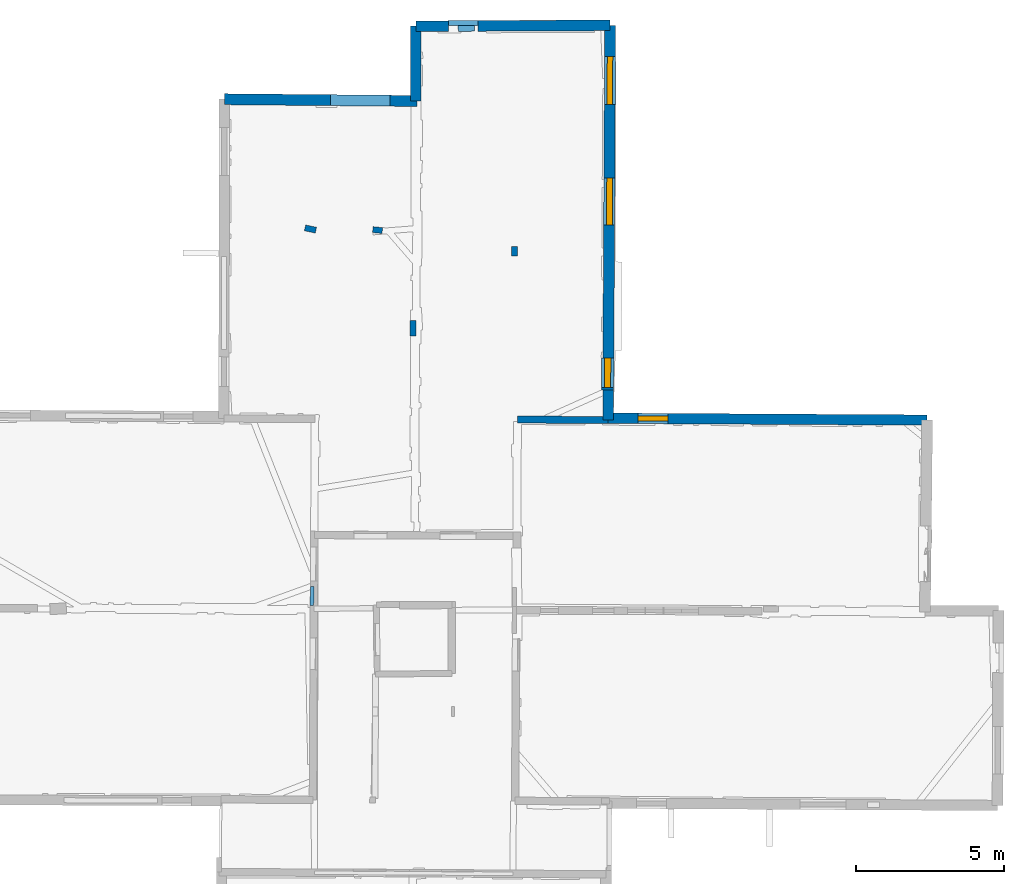
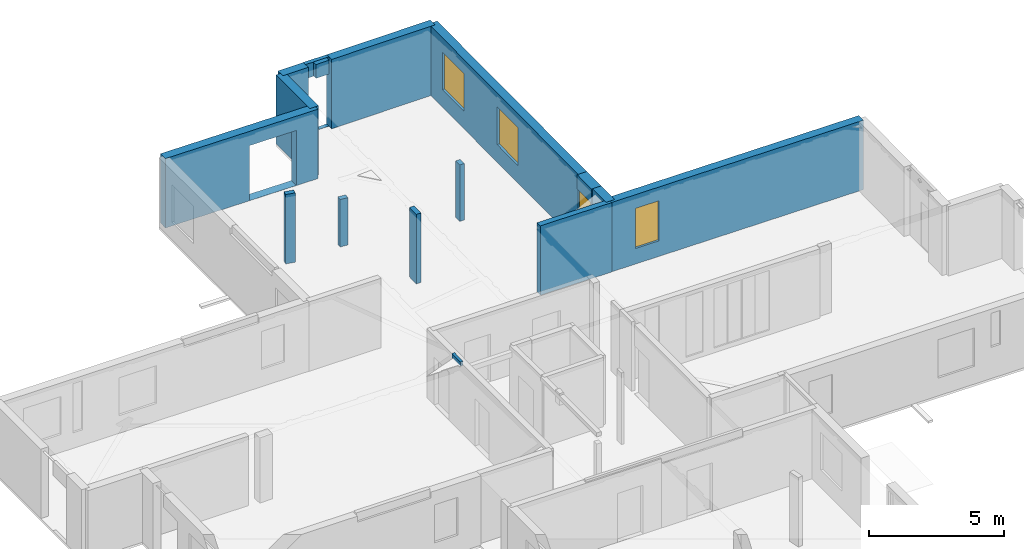
# One storey, part 9 of 14: 16 walls, 4 windows, 6 openings.
"""IFC2X3 building model written with IfcOpenShell, lengths in metres."""

import ifcopenshell
import ifcopenshell.guid

model = None  # the IFC model being written
_history = None  # IfcOwnerHistory: only IFC2X3 demands one
_inside = {}  # id of a spatial element -> (the spatial element, [elements in it])
_under = {}  # id of a project, library or spatial element -> (it, [spatial elements below it])
_declared = {}  # id of a project -> (the project, [libraries it declares])
_typed = {}  # id of a type object -> (the type object, [elements of that type])
_made_of = {}  # id of a material, layer set ... -> (it, [elements and type objects made of it])


def new_model(schema):
    """Start an empty IFC model of exactly this schema.

    Asked for "IFC4X3", IfcOpenShell would pick the latest addendum, in which some entities
    have other attributes; the version numbers below select the first issue.
    IFC2X3 requires an IfcOwnerHistory on every rooted entity: one is made here for all.
    """
    global model, _history
    if schema == "IFC4X3":
        model = ifcopenshell.file(schema_version=(4, 3, 0, 0))
    else:
        model = ifcopenshell.file(schema=schema)
    _inside.clear()
    _under.clear()
    _declared.clear()
    _typed.clear()
    _made_of.clear()
    _history = None
    if model.schema == "IFC2X3":
        org = make("IfcOrganization", Name="unknown")
        user = make(
            "IfcPersonAndOrganization",
            ThePerson=make("IfcPerson", FamilyName="unknown"),
            TheOrganization=org,
        )
        app = make(
            "IfcApplication",
            ApplicationDeveloper=org,
            Version="unknown",
            ApplicationFullName="unknown",
            ApplicationIdentifier="unknown",
        )
        _history = make(
            "IfcOwnerHistory",
            OwningUser=user,
            OwningApplication=app,
            ChangeAction="ADDED",
            CreationDate=0,
        )
    return model


def make(cls, **values):
    """One entity of the class cls with the attributes given. An attribute that is None is left unset."""
    return model.create_entity(
        cls, **{name: value for name, value in values.items() if value is not None}
    )


def entity(cls, *values):
    """Any entity or typed value of the class cls, its attributes in the order of the schema. None: left unset."""
    e = model.create_entity(cls)
    for i, value in enumerate(values):
        if value is not None:
            e[i] = value
    return e


def rooted(cls, **values):
    """An entity with a GlobalId (a new one), such as an element, a storey or a relation."""
    return make(cls, GlobalId=ifcopenshell.guid.new(), OwnerHistory=_history, **values)


def si_unit(unit_type, name, prefix=None):
    """IfcSIUnit, for example si_unit("LENGTHUNIT", "METRE", prefix="MILLI")."""
    return make("IfcSIUnit", UnitType=unit_type, Prefix=prefix, Name=name)


def converted_unit(unit_type, name, factor, base, dimensions=None, offset=None):
    """IfcConversionBasedUnit, such as the inch: factor (a typed value) times the base unit."""
    return make(
        "IfcConversionBasedUnit"
        if offset is None
        else "IfcConversionBasedUnitWithOffset",
        ConversionOffset=offset,
        Dimensions=None
        if dimensions is None
        else entity("IfcDimensionalExponents", *dimensions),
        UnitType=unit_type,
        Name=name,
        ConversionFactor=make(
            "IfcMeasureWithUnit", ValueComponent=factor, UnitComponent=base
        ),
    )


def derived_unit(unit_type, elements):
    """IfcDerivedUnit: a product of units, each with its exponent."""
    return make(
        "IfcDerivedUnit",
        Elements=[
            make("IfcDerivedUnitElement", Unit=unit, Exponent=power)
            for unit, power in elements
        ],
        UnitType=unit_type,
    )


def assignment(units):
    """IfcUnitAssignment: the units of a project."""
    return None if units is None else make("IfcUnitAssignment", Units=units)


def point(xyz):
    """IfcCartesianPoint."""
    return None if xyz is None else make("IfcCartesianPoint", Coordinates=xyz)


def direction(xyz):
    """IfcDirection."""
    return None if xyz is None else make("IfcDirection", DirectionRatios=xyz)


def frame(location, z_axis=None, x_axis=None):
    """IfcAxis2Placement3D, a coordinate frame: its origin and axes. An axis left out is left unset."""
    return make(
        "IfcAxis2Placement3D",
        Location=point(location),
        Axis=direction(z_axis),
        RefDirection=direction(x_axis),
    )


def frame_2d(location, x_axis=None):
    """IfcAxis2Placement2D, a coordinate frame in the plane: its origin and x axis."""
    return make(
        "IfcAxis2Placement2D", Location=point(location), RefDirection=direction(x_axis)
    )


def origin():
    """The frame at (0, 0, 0) with its axes left unset."""
    return frame((0.0, 0.0, 0.0))


def origin_2d_with_axis():
    """The frame at (0, 0) in the plane with the x axis (1, 0) written out."""
    return frame_2d((0.0, 0.0), x_axis=(1.0, 0.0))


def place(relative_to, where):
    """IfcLocalPlacement: puts the frame where relative to a parent placement (None: the world)."""
    return make(
        "IfcLocalPlacement", PlacementRelTo=relative_to, RelativePlacement=where
    )


def context(
    kind, dimensions, precision=None, world=None, true_north=None, identifier=None
):
    """IfcGeometricRepresentationContext, for example the 3D "Model" context."""
    return make(
        "IfcGeometricRepresentationContext",
        ContextIdentifier=identifier,
        ContextType=kind,
        CoordinateSpaceDimension=dimensions,
        Precision=precision,
        WorldCoordinateSystem=world,
        TrueNorth=true_north,
    )


def subcontext(parent, identifier, kind, view, scale=None):
    """IfcGeometricRepresentationSubContext, for example "Body" below "Model"."""
    return make(
        "IfcGeometricRepresentationSubContext",
        ContextIdentifier=identifier,
        ContextType=kind,
        ParentContext=parent,
        TargetScale=scale,
        TargetView=view,
    )


def project(units=None, contexts=None):
    """IfcProject with its units and contexts."""
    return rooted(
        "IfcProject",
        Name="project",
        RepresentationContexts=contexts,
        UnitsInContext=assignment(units),
    )


def spatial(cls, under=None, at=None, **own):
    """A site, building, storey or space (cls), placed at a placement, below another one or the project."""
    s = rooted(cls, ObjectPlacement=at, **own)
    if under is not None:
        _under.setdefault(under.id(), (under, []))[1].append(s)
    return s


def polyline(points):
    """IfcPolyline through the points."""
    return make("IfcPolyline", Points=[point(p) for p in points])


def profile(cls, at=None, kind="AREA", **sizes):
    """A parametric profile (cls). Its sizes go by their IFC names, for example OverallWidth=200.0."""
    return make(cls, ProfileType=kind, Position=at, **sizes)


def rectangle(**sizes):
    """IfcRectangleProfileDef."""
    return profile("IfcRectangleProfileDef", **sizes)


def outline(outer, holes=None, kind="AREA"):
    """IfcArbitraryClosedProfileDef: a profile drawn as a closed curve; with holes, ...WithVoids."""
    if holes is None:
        return make("IfcArbitraryClosedProfileDef", ProfileType=kind, OuterCurve=outer)
    return make(
        "IfcArbitraryProfileDefWithVoids",
        ProfileType=kind,
        OuterCurve=outer,
        InnerCurves=holes,
    )


def extrude(swept, where, along, depth):
    """IfcExtrudedAreaSolid: the profile swept, set in the frame where, extruded along a direction by depth."""
    return make(
        "IfcExtrudedAreaSolid",
        SweptArea=swept,
        Position=where,
        ExtrudedDirection=direction(along),
        Depth=depth,
    )


def shape(context_of_items, identifier, shape_type, items):
    """IfcShapeRepresentation: the items that make up one representation, for example the "Body"."""
    return make(
        "IfcShapeRepresentation",
        ContextOfItems=context_of_items,
        RepresentationIdentifier=identifier,
        RepresentationType=shape_type,
        Items=items,
    )


def source(mapping_origin, context_of_items, identifier, shape_type, items):
    """IfcRepresentationMap: a shape defined once, which mapped items show again and again."""
    return make(
        "IfcRepresentationMap",
        MappingOrigin=mapping_origin,
        MappedRepresentation=shape(context_of_items, identifier, shape_type, items),
    )


def transform(
    local_origin,
    x_axis=None,
    y_axis=None,
    z_axis=None,
    scale=None,
    scale2=None,
    scale3=None,
    uniform=True,
):
    """IfcCartesianTransformationOperator3D, or its non-uniform kind. x_axis, y_axis, z_axis: its Axis1, 2, 3."""
    if uniform:
        return make(
            "IfcCartesianTransformationOperator3D",
            Axis1=direction(x_axis),
            Axis2=direction(y_axis),
            LocalOrigin=point(local_origin),
            Scale=scale,
            Axis3=direction(z_axis),
        )
    return make(
        "IfcCartesianTransformationOperator3DnonUniform",
        Axis1=direction(x_axis),
        Axis2=direction(y_axis),
        LocalOrigin=point(local_origin),
        Scale=scale,
        Axis3=direction(z_axis),
        Scale2=scale2,
        Scale3=scale3,
    )


def mapped(mapping_source, mapping_target):
    """IfcMappedItem: shows the shape of a source again, moved by a transform."""
    return make(
        "IfcMappedItem", MappingSource=mapping_source, MappingTarget=mapping_target
    )


def material(Name=None, Category=None):
    """IfcMaterial."""
    return make("IfcMaterial", Name=Name, Category=Category)


def layer(
    of_material, thickness, ventilated=None, Name=None, Category=None, Priority=None
):
    """IfcMaterialLayer: one layer of a wall or slab, of a material (None: an air gap)."""
    return make(
        "IfcMaterialLayer",
        Material=of_material,
        LayerThickness=thickness,
        IsVentilated=ventilated,
        Name=Name,
        Category=Category,
        Priority=Priority,
    )


def layer_set(layers, Name=None):
    """IfcMaterialLayerSet."""
    return make("IfcMaterialLayerSet", MaterialLayers=layers, LayerSetName=Name)


def layer_usage(for_layer_set, set_direction, sense, offset, extent=None):
    """IfcMaterialLayerSetUsage: how a layer set lies in its element."""
    return make(
        "IfcMaterialLayerSetUsage",
        ForLayerSet=for_layer_set,
        LayerSetDirection=set_direction,
        DirectionSense=sense,
        OffsetFromReferenceLine=offset,
        ReferenceExtent=extent,
    )


def made_of(thing, what):
    """Note that an element or type object is made of a material, layer set ...; save() writes the relation."""
    if what is not None:
        _made_of.setdefault(what.id(), (what, []))[1].append(thing)
    return thing


def type_object(cls, material=None, **own):
    """A type object (cls), such as IfcWallType, which elements share."""
    return made_of(rooted(cls, **own), material)


def type_shapes(of_type, sources):
    """Give a type object the sources (RepresentationMaps) that its elements show as mapped items."""
    of_type.RepresentationMaps = sources


def element(
    cls,
    number,
    at=None,
    inside=None,
    cuts=None,
    type_object=None,
    material=None,
    context=None,
    identifier="Body",
    shape_type=None,
    held_by="IfcProductDefinitionShape",
    body=None,
    shapes=None,
    **own,
):
    """One element of the class cls, such as IfcWall. Its Tag is "e" and its number.

    at: its placement. inside: the storey or other place that contains it. cuts: it is an
    opening in that element (IfcRelVoidsElement). A single representation is given by context,
    identifier, shape_type and body (its items); several are given by shapes. held_by: the class
    of the entity that holds the representations. save() writes the other relations.
    """
    e = rooted(cls, Tag="e%d" % number, ObjectPlacement=at, **own)
    if body is not None:
        shapes = [shape(context, identifier, shape_type, body)]
    if shapes is not None:
        e.Representation = make(held_by, Representations=shapes)
    if inside is not None:
        _inside.setdefault(inside.id(), (inside, []))[1].append(e)
    if cuts is not None:
        rooted(
            "IfcRelVoidsElement", RelatingBuildingElement=cuts, RelatedOpeningElement=e
        )
    if type_object is not None:
        _typed.setdefault(type_object.id(), (type_object, []))[1].append(e)
    return made_of(e, material)


def fill(opening, filler):
    """IfcRelFillsElement: the door or window that sits in an opening."""
    return rooted(
        "IfcRelFillsElement",
        RelatingOpeningElement=opening,
        RelatedBuildingElement=filler,
    )


def aggregate(whole, parts):
    """IfcRelAggregates: a whole, such as a stair, and the parts it consists of."""
    return rooted("IfcRelAggregates", RelatingObject=whole, RelatedObjects=parts)


def save(model, path):
    """Write the relations noted so far, then the file.

    IfcRelAggregates (storeys below a building ...), IfcRelContainedInSpatialStructure (elements
    in a storey), IfcRelDefinesByType, IfcRelAssociatesMaterial and IfcRelDeclares: one each for
    every whole, place, type object, material and project.
    """
    for whole, parts in _under.values():
        aggregate(whole, parts)
    for where, things in _inside.values():
        rooted(
            "IfcRelContainedInSpatialStructure",
            RelatedElements=things,
            RelatingStructure=where,
        )
    for kind, things in _typed.values():
        rooted("IfcRelDefinesByType", RelatedObjects=things, RelatingType=kind)
    for what, things in _made_of.values():
        rooted("IfcRelAssociatesMaterial", RelatedObjects=things, RelatingMaterial=what)
    for by, libraries in _declared.values():
        rooted("IfcRelDeclares", RelatingContext=by, RelatedDefinitions=libraries)
    model.write(path)


model = new_model("IFC2X3")

# Units and contexts
model_context = context("Model", 3, precision=1e-05, world=origin(), true_north=direction((0.0, 1.0)))
body_context = subcontext(model_context, "Body", "Model", "MODEL_VIEW")
ifc_project = project(units=[si_unit("LENGTHUNIT", "METRE"), si_unit("AREAUNIT", "SQUARE_METRE"), si_unit("VOLUMEUNIT", "CUBIC_METRE"), converted_unit("PLANEANGLEUNIT", "DEGREE", entity("IfcRatioMeasure", 0.0174532925199433), si_unit("PLANEANGLEUNIT", "RADIAN"), dimensions=[0, 0, 0, 0, 0, 0, 0]), si_unit("MASSUNIT", "GRAM", prefix="KILO"), derived_unit("MASSDENSITYUNIT", [(si_unit("MASSUNIT", "GRAM", prefix="KILO"), 1), (si_unit("LENGTHUNIT", "METRE"), -3)]), derived_unit("MOMENTOFINERTIAUNIT", [(si_unit("LENGTHUNIT", "METRE"), 4)]), si_unit("TIMEUNIT", "SECOND"), si_unit("FREQUENCYUNIT", "HERTZ"), si_unit("THERMODYNAMICTEMPERATUREUNIT", "DEGREE_CELSIUS"), derived_unit("THERMALTRANSMITTANCEUNIT", [(si_unit("MASSUNIT", "GRAM", prefix="KILO"), 1), (si_unit("THERMODYNAMICTEMPERATUREUNIT", "KELVIN"), -1), (si_unit("TIMEUNIT", "SECOND"), -3)]), derived_unit("VOLUMETRICFLOWRATEUNIT", [(si_unit("LENGTHUNIT", "METRE"), 3), (si_unit("TIMEUNIT", "SECOND"), -1)]), si_unit("ELECTRICCURRENTUNIT", "AMPERE"), si_unit("ELECTRICVOLTAGEUNIT", "VOLT"), si_unit("POWERUNIT", "WATT"), si_unit("FORCEUNIT", "NEWTON", prefix="KILO"), si_unit("ILLUMINANCEUNIT", "LUX"), si_unit("LUMINOUSFLUXUNIT", "LUMEN"), si_unit("LUMINOUSINTENSITYUNIT", "CANDELA"), derived_unit("USERDEFINED", [(si_unit("MASSUNIT", "GRAM", prefix="KILO"), -1), (si_unit("LENGTHUNIT", "METRE"), -2), (si_unit("TIMEUNIT", "SECOND"), 3), (si_unit("LUMINOUSFLUXUNIT", "LUMEN"), 1)]), derived_unit("LINEARVELOCITYUNIT", [(si_unit("LENGTHUNIT", "METRE"), 1), (si_unit("TIMEUNIT", "SECOND"), -1)]), si_unit("PRESSUREUNIT", "PASCAL"), derived_unit("USERDEFINED", [(si_unit("LENGTHUNIT", "METRE"), -2), (si_unit("MASSUNIT", "GRAM", prefix="KILO"), 1), (si_unit("TIMEUNIT", "SECOND"), -2)]), derived_unit("LINEARFORCEUNIT", [(si_unit("MASSUNIT", "GRAM", prefix="KILO"), 1), (si_unit("LENGTHUNIT", "METRE"), 1), (si_unit("TIMEUNIT", "SECOND"), -2), (si_unit("LENGTHUNIT", "METRE"), -1)]), derived_unit("PLANARFORCEUNIT", [(si_unit("MASSUNIT", "GRAM", prefix="KILO"), 1), (si_unit("LENGTHUNIT", "METRE"), 1), (si_unit("TIMEUNIT", "SECOND"), -2), (si_unit("LENGTHUNIT", "METRE"), -2)])], contexts=[model_context])

# Site, building, storey
placement_1 = place(None, origin())
site = spatial("IfcSite", under=ifc_project, at=placement_1, CompositionType="ELEMENT")
building = spatial("IfcBuilding", under=site, at=placement_1, CompositionType="ELEMENT")
storey_placement = place(placement_1, frame((0.0, 0.0, 8.83152770996094)))
storey = spatial("IfcBuildingStorey", under=building, at=storey_placement, Name="Level 4", CompositionType="ELEMENT", Elevation=8.83152770996094)

# Wall, opening, window
ifc_material_1 = material(Name="Default wall")
ifc_layer_1 = layer(ifc_material_1, 0.349999994039536)
ifc_layer_set_1 = layer_set([ifc_layer_1], Name="wall_thickness_0.3500")
ifc_layer_usage_1 = layer_usage(ifc_layer_set_1, "AXIS2", "POSITIVE", -0.174999997019768)
wall_type_1 = type_object("IfcWallType", Name="wall_thickness_0.3500", PredefinedType="STANDARD", material=ifc_layer_set_1)
wall_1_placement = place(storey_placement, frame((12.8912409247061, 64.0954420276395, 0.0), z_axis=(0.0, 0.0, 1.0), x_axis=(0.999983571319247, -0.00573211057163391, 0.0)))
wall_1 = element("IfcWallStandardCase", 1, at=wall_1_placement, inside=storey, type_object=wall_type_1, material=ifc_layer_usage_1, Name="Wall:393", ObjectType="Wall", context=body_context, shape_type="SweptSolid", body=[
    extrude(outline(polyline([(10.7557480681077, -0.174999997019768), (10.7557480681077, 0.174999997019768), (0.0, 0.174999997019768), (0.0, -0.174999997019768), (10.7557480681077, -0.174999997019768)])), origin(), (0.0, 0.0, 1.0), 3.14668312072754),
])
opening_1_placement = place(wall_1_placement, frame((1.00914543612065, -0.174999997019768, 0.705471992492676)))
opening_1 = element("IfcOpeningElement", 2, at=opening_1_placement, cuts=wall_1, Name="Opening : 1005 x 1820 : 318", ObjectType="Opening", context=body_context, shape_type="SweptSolid", body=[
    extrude(rectangle(XDim=1.005, YDim=1.82, at=frame_2d((0.91, 0.5025), x_axis=(0.0, 1.0))), frame((0.0, 0.0, 0.0), z_axis=(0.0, 1.0, 0.0), x_axis=(0.0, 0.0, 1.0)), (0.0, 0.0, 1.0), 0.349999994039536),
])
ifc_material_2 = material(Name="Window Default")
window_style_1 = type_object("IfcWindowStyle", Name="Window : 1005 x 1820mm", ConstructionType="NOTDEFINED", OperationType="NOTDEFINED", ParameterTakesPrecedence=False, Sizeable=False, material=ifc_material_2)
shared_shape_1 = source(origin(), body_context, "Body", "SweptSolid", [
    extrude(rectangle(XDim=0.174999997019768, YDim=1.005, at=origin_2d_with_axis()), frame((0.5025, 0.174999997019768, 0.0), z_axis=(0.0, 0.0, 1.0), x_axis=(0.0, 1.0, 0.0)), (0.0, 0.0, 1.0), 1.82),
])
type_shapes(window_style_1, [shared_shape_1])
window_1_placement = place(opening_1_placement, origin())
window_1 = element("IfcWindow", 3, at=window_1_placement, inside=storey, type_object=window_style_1, Name="Window : 1005 x 1820mm : 171", ObjectType="Window : 1005 x 1820mm", OverallHeight=1.82, OverallWidth=1.005, context=body_context, shape_type="MappedRepresentation", body=[
    mapped(shared_shape_1, transform((0.0, 0.0, 0.0), scale=1.0)),
])
fill(opening_1, window_1)

# Walls
ifc_layer_2 = layer(ifc_material_1, 0.2)
ifc_layer_set_2 = layer_set([ifc_layer_2], Name="wall_thickness_0.2000")
ifc_layer_usage_2 = layer_usage(ifc_layer_set_2, "AXIS2", "POSITIVE", -0.1)
wall_type_2 = type_object("IfcWallType", Name="wall_thickness_0.2000", PredefinedType="STANDARD", material=ifc_layer_set_2)
wall_2_placement = place(storey_placement, frame((6.31049606860338, 67.3984193404147, 0.0), z_axis=(0.0, 0.0, 1.0), x_axis=(-0.00964204558644197, -0.999953514397999, 0.0)))
element("IfcWallStandardCase", 4, at=wall_2_placement, inside=storey, type_object=wall_type_2, material=ifc_layer_usage_2, Name="Wall:374", ObjectType="Wall", context=body_context, shape_type="SweptSolid", body=[
    extrude(outline(polyline([(0.525003042777808, -0.1), (0.525003042777808, 0.1), (0.0, 0.1), (0.0, -0.1), (0.525003042777808, -0.1)])), origin(), (0.0, 0.0, 1.0), 3.14668312072754),
])
wall_3_placement = place(storey_placement, frame((3.03429582295664, 70.4372123065783, 0.0), z_axis=(0.0, 0.0, 1.0), x_axis=(-0.977652852682514, 0.210225830101208, 0.0)))
element("IfcWallStandardCase", 5, at=wall_3_placement, inside=storey, type_object=wall_type_2, material=ifc_layer_usage_2, Name="Wall:396", ObjectType="Wall", context=body_context, shape_type="SweptSolid", body=[
    extrude(outline(polyline([(0.374999274130363, -0.1), (0.374999274130363, 0.1), (0.0, 0.1), (0.0, -0.1), (0.374999274130363, -0.1)])), origin(), (0.0, 0.0, 1.0), 3.14668312072754),
])
wall_4_placement = place(storey_placement, frame((9.72516008895477, 69.8813732674377, 0.0), z_axis=(0.0, 0.0, 1.0), x_axis=(0.00111717904463725, -0.999999375955296, 0.0)))
element("IfcWallStandardCase", 6, at=wall_4_placement, inside=storey, type_object=wall_type_2, material=ifc_layer_usage_2, Name="Wall:400", ObjectType="Wall", context=body_context, shape_type="SweptSolid", body=[
    extrude(outline(polyline([(0.314995008582686, -0.1), (0.314995008582686, 0.1), (0.0, 0.1), (0.0, -0.1), (0.314995008582686, -0.1)])), origin(), (0.0, 0.0, 1.0), 2.56147193908691),
])
placement_2 = place(placement_1, frame((0.0, 0.0, 11.3549995422363)))
wall_5_placement = place(placement_2, frame((7.83411944431385, 77.2447593697518, 0.0), z_axis=(0.0, 0.0, 1.0), x_axis=(0.999992379159256, 0.00390405217834683, 0.0)))
element("IfcWallStandardCase", 7, at=wall_5_placement, inside=storey, type_object=wall_type_2, material=ifc_layer_usage_2, Name="Wall:403", ObjectType="Wall", context=body_context, shape_type="SweptSolid", body=[
    extrude(outline(polyline([(0.554999766369032, -0.1), (0.554999766369032, 0.1), (0.0, 0.1), (0.0, -0.1), (0.554999766369032, -0.1)])), origin(), (0.0, 0.0, 1.0), 0.623211288452149),
])
wall_6_placement = place(storey_placement, frame((5.27301931064714, 70.4258220730206, 0.0), z_axis=(0.0, 0.0, 1.0), x_axis=(-0.995304049747342, 0.0967979780601873, 0.0)))
element("IfcWallStandardCase", 8, at=wall_6_placement, inside=storey, type_object=wall_type_2, material=ifc_layer_usage_2, Name="Wall:487", ObjectType="Wall", context=body_context, shape_type="SweptSolid", body=[
    extrude(outline(polyline([(0.319999884477081, -0.1), (0.319999884477081, 0.1), (0.0, 0.1), (0.0, -0.1), (0.319999884477081, -0.1)])), origin(), (0.0, 0.0, 1.0), 2.1514720916748),
])
ifc_layer_3 = layer(ifc_material_1, 0.239999994635582)
ifc_layer_set_3 = layer_set([ifc_layer_3], Name="wall_thickness_0.2400")
ifc_layer_usage_3 = layer_usage(ifc_layer_set_3, "AXIS2", "POSITIVE", -0.119999997317791)
wall_type_3 = type_object("IfcWallType", Name="wall_thickness_0.2400", PredefinedType="STANDARD", material=ifc_layer_set_3)
wall_7_placement = place(storey_placement, frame((9.82888713184633, 64.0535260272642, 0.0), z_axis=(0.0, 0.0, 1.0), x_axis=(0.999974397034558, -0.0071557861463554, 0.0)))
element("IfcWallStandardCase", 9, at=wall_7_placement, inside=storey, type_object=wall_type_3, material=ifc_layer_usage_3, Name="Wall:438", ObjectType="Wall", context=body_context, shape_type="SweptSolid", body=[
    extrude(outline(polyline([(3.06208439514505, -0.119999997317791), (3.06208439514505, 0.119999997317791), (0.0, 0.119999997317791), (0.0, -0.119999997317791), (3.06208439514505, -0.119999997317791)])), origin(), (0.0, 0.0, 1.0), 3.14668312072754),
])
ifc_layer_4 = layer(ifc_material_1, 0.119999997317791)
ifc_layer_set_4 = layer_set([ifc_layer_4], Name="wall_thickness_0.1200")
ifc_layer_usage_4 = layer_usage(ifc_layer_set_4, "AXIS2", "POSITIVE", -0.0599999986588955)
wall_type_4 = type_object("IfcWallType", Name="wall_thickness_0.1200", PredefinedType="STANDARD", material=ifc_layer_set_4)
placement_3 = place(placement_1, frame((0.0, 0.0, 11.7930002212524)))
wall_8_placement = place(placement_3, frame((2.90615101010984, 58.4169673938861, 0.0), z_axis=(0.0, 0.0, 1.0), x_axis=(-0.00893267893944171, -0.99996010282759, 0.0)))
element("IfcWallStandardCase", 10, at=wall_8_placement, inside=storey, type_object=wall_type_4, material=ifc_layer_usage_4, Name="Wall:375", ObjectType="Wall", context=body_context, shape_type="SweptSolid", body=[
    extrude(outline(polyline([(0.640948118404304, -0.0599999986588955), (0.640948118404304, 0.0599999986588955), (0.0, 0.0599999986588955), (0.0, -0.0599999986588955), (0.640948118404304, -0.0599999986588955)])), origin(), (0.0, 0.0, 1.0), 0.185210609436036),
])

# Wall, openings, windows
ifc_layer_5 = layer(ifc_material_1, 0.370000004768372)
ifc_layer_set_5 = layer_set([ifc_layer_5], Name="wall_thickness_0.3700")
ifc_layer_usage_5 = layer_usage(ifc_layer_set_5, "AXIS2", "POSITIVE", -0.185000002384186)
wall_type_5 = type_object("IfcWallType", Name="wall_thickness_0.3700", PredefinedType="STANDARD", material=ifc_layer_set_5)
wall_9_placement = place(storey_placement, frame((12.9586795196594, 77.3458828359282, 0.0), z_axis=(0.0, 0.0, 1.0), x_axis=(-0.00546654665595545, -0.999985058322202, 0.0)))
wall_9 = element("IfcWallStandardCase", 11, at=wall_9_placement, inside=storey, type_object=wall_type_5, material=ifc_layer_usage_5, Name="Wall:441", ObjectType="Wall", context=body_context, shape_type="SweptSolid", body=[
    extrude(outline(polyline([(11.2262724756743, -0.185000002384186), (11.2262724756743, 0.185000002384186), (0.0, 0.185000002384186), (0.0, -0.185000002384186), (11.2262724756743, -0.185000002384186)])), origin(), (0.0, 0.0, 1.0), 3.14668312072754),
])
opening_2_placement = place(wall_9_placement, frame((5.14127402636816, -0.185000002384186, 0.800472259521484)))
opening_2 = element("IfcOpeningElement", 12, at=opening_2_placement, cuts=wall_9, Name="Opening : 1590 x 1710 : 343", ObjectType="Opening", context=body_context, shape_type="SweptSolid", body=[
    extrude(rectangle(XDim=1.59, YDim=1.71, at=frame_2d((0.855, 0.795), x_axis=(0.0, 1.0))), frame((0.0, 0.0, 0.0), z_axis=(0.0, 1.0, 0.0), x_axis=(0.0, 0.0, 1.0)), (0.0, 0.0, 1.0), 0.370000004768372),
])
opening_3_placement = place(wall_9_placement, frame((1.04627265418647, -0.185000002384186, 0.800472259521484)))
opening_3 = element("IfcOpeningElement", 13, at=opening_3_placement, cuts=wall_9, Name="Opening : 1620 x 1700 : 344", ObjectType="Opening", context=body_context, shape_type="SweptSolid", body=[
    extrude(rectangle(XDim=1.62, YDim=1.7, at=frame_2d((0.85, 0.81), x_axis=(0.0, 1.0))), frame((0.0, 0.0, 0.0), z_axis=(0.0, 1.0, 0.0), x_axis=(0.0, 0.0, 1.0)), (0.0, 0.0, 1.0), 0.370000004768372),
])
window_style_2 = type_object("IfcWindowStyle", Name="Window : 1590 x 1710mm", ConstructionType="NOTDEFINED", OperationType="NOTDEFINED", ParameterTakesPrecedence=False, Sizeable=False, material=ifc_material_2)
shared_shape_2 = source(origin(), body_context, "Body", "SweptSolid", [
    extrude(rectangle(XDim=0.194999992847443, YDim=1.59, at=origin_2d_with_axis()), frame((0.795, 0.194999992847443, 0.0), z_axis=(0.0, 0.0, 1.0), x_axis=(0.0, 1.0, 0.0)), (0.0, 0.0, 1.0), 1.71),
])
type_shapes(window_style_2, [shared_shape_2])
window_2_placement = place(opening_2_placement, origin())
window_2 = element("IfcWindow", 14, at=window_2_placement, inside=storey, type_object=window_style_2, Name="Window : 1590 x 1710mm : 184", ObjectType="Window : 1590 x 1710mm", OverallHeight=1.71, OverallWidth=1.59, context=body_context, shape_type="MappedRepresentation", body=[
    mapped(shared_shape_2, transform((0.0, 0.0, 0.0), scale=1.0)),
])
fill(opening_2, window_2)
window_style_3 = type_object("IfcWindowStyle", Name="Window : 1620 x 1700mm", ConstructionType="NOTDEFINED", OperationType="NOTDEFINED", ParameterTakesPrecedence=False, Sizeable=False, material=ifc_material_2)
shared_shape_3 = source(origin(), body_context, "Body", "SweptSolid", [
    extrude(rectangle(XDim=0.185000002384186, YDim=1.62, at=origin_2d_with_axis()), frame((0.81, 0.185000002384186, 0.0), z_axis=(0.0, 0.0, 1.0), x_axis=(0.0, 1.0, 0.0)), (0.0, 0.0, 1.0), 1.7),
])
type_shapes(window_style_3, [shared_shape_3])
window_3_placement = place(opening_3_placement, origin())
window_3 = element("IfcWindow", 15, at=window_3_placement, inside=storey, type_object=window_style_3, Name="Window : 1620 x 1700mm : 185", ObjectType="Window : 1620 x 1700mm", OverallHeight=1.7, OverallWidth=1.62, context=body_context, shape_type="MappedRepresentation", body=[
    mapped(shared_shape_3, transform((0.0, 0.0, 0.0), scale=1.0)),
])
fill(opening_3, window_3)

# Wall, opening
wall_10_placement = place(storey_placement, frame((-0.0536872110357355, 74.8548942704265, 0.0), z_axis=(0.0, 0.0, 1.0), x_axis=(0.999957855622248, -0.00918079404819617, 0.0)))
wall_10 = element("IfcWallStandardCase", 16, at=wall_10_placement, inside=storey, type_object=wall_type_5, material=ifc_layer_usage_5, Name="Wall:484", ObjectType="Wall", context=body_context, shape_type="SweptSolid", body=[
    extrude(outline(polyline([(6.50519988544556, -0.185000002384186), (6.50519988544556, 0.185000002384186), (0.0, 0.185000002384186), (0.0, -0.185000002384186), (6.50519988544556, -0.185000002384186)])), origin(), (0.0, 0.0, 1.0), 3.14668312072754),
])
opening_4_placement = place(wall_10_placement, frame((3.57643579648773, -0.185000002384186, 0.00547218322753906)))
element("IfcOpeningElement", 17, at=opening_4_placement, cuts=wall_10, Name="Opening : 2010 x 2495 : 377", ObjectType="Opening", context=body_context, shape_type="SweptSolid", body=[
    extrude(rectangle(XDim=2.01, YDim=2.495, at=frame_2d((1.2475, 1.005), x_axis=(0.0, 1.0))), frame((0.0, 0.0, 0.0), z_axis=(0.0, 1.0, 0.0), x_axis=(0.0, 0.0, 1.0)), (0.0, 0.0, 1.0), 0.370000004768372),
])

# Walls
ifc_layer_6 = layer(ifc_material_1, 0.360000014305115)
ifc_layer_set_6 = layer_set([ifc_layer_6], Name="wall_thickness_0.3600")
ifc_layer_usage_6 = layer_usage(ifc_layer_set_6, "AXIS2", "POSITIVE", -0.180000007152557)
wall_type_6 = type_object("IfcWallType", Name="wall_thickness_0.3600", PredefinedType="STANDARD", material=ifc_layer_set_6)
wall_11_placement = place(storey_placement, frame((6.40318411230785, 77.3155692474924, 0.0), z_axis=(0.0, 0.0, 1.0), x_axis=(0.999989243152977, 0.00463827320621391, 0.0)))
element("IfcWallStandardCase", 18, at=wall_11_placement, inside=storey, type_object=wall_type_6, material=ifc_layer_usage_6, Name="Wall:421", ObjectType="Wall", context=body_context, shape_type="SweptSolid", body=[
    extrude(outline(polyline([(1.0954888881934, -0.180000007152557), (1.0954888881934, 0.180000007152557), (0.0, 0.180000007152557), (0.0, -0.180000007152557), (1.0954888881934, -0.180000007152557)])), origin(), (0.0, 0.0, 1.0), 3.14668312072754),
])
wall_12_placement = place(storey_placement, frame((8.49861954532449, 77.3252509394619, 0.0), z_axis=(0.0, 0.0, 1.0), x_axis=(0.999989302676444, 0.00462542243257588, 0.0)))
element("IfcWallStandardCase", 19, at=wall_12_placement, inside=storey, type_object=wall_type_6, material=ifc_layer_usage_6, Name="Wall:422", ObjectType="Wall", context=body_context, shape_type="SweptSolid", body=[
    extrude(outline(polyline([(4.46010783084547, -0.180000007152557), (4.46010783084547, 0.180000007152557), (0.0, 0.180000007152557), (0.0, -0.180000007152557), (4.46010783084547, -0.180000007152557)])), origin(), (0.0, 0.0, 1.0), 3.14668312072754),
])
wall_13_placement = place(storey_placement, frame((12.8964568451286, 65.0492704496143, 0.0), z_axis=(0.0, 0.0, 1.0), x_axis=(-0.0054670927571975, -0.999985055336721, 0.0)))
element("IfcWallStandardCase", 20, at=wall_13_placement, inside=storey, type_object=wall_type_6, material=ifc_layer_usage_6, Name="Wall:443", ObjectType="Wall", context=body_context, shape_type="SweptSolid", body=[
    extrude(outline(polyline([(1.01767725718378, -0.180000007152557), (1.01767725718378, 0.180000007152557), (0.0, 0.180000007152557), (0.0, -0.180000007152557), (1.01767725718378, -0.180000007152557)])), origin(), (0.0, 0.0, 1.0), 3.14668312072754),
])
wall_14_placement = place(storey_placement, frame((6.40318266006841, 77.3155919784668, 0.0), z_axis=(0.0, 0.0, 1.0), x_axis=(-0.00236211499385346, -0.999997210202486, 0.0)))
element("IfcWallStandardCase", 21, at=wall_14_placement, inside=storey, type_object=wall_type_6, material=ifc_layer_usage_6, Name="Wall:492", ObjectType="Wall", context=body_context, shape_type="SweptSolid", body=[
    extrude(outline(polyline([(2.51992737920823, -0.180000007152557), (2.51992737920823, 0.180000007152557), (0.0, 0.180000007152557), (0.0, -0.180000007152557), (2.51992737920823, -0.180000007152557)])), origin(), (0.0, 0.0, 1.0), 3.14668312072754),
])

# Wall, opening
ifc_layer_7 = layer(ifc_material_1, 0.170000001788139)
ifc_layer_set_7 = layer_set([ifc_layer_7], Name="wall_thickness_0.1700")
ifc_layer_usage_7 = layer_usage(ifc_layer_set_7, "AXIS2", "POSITIVE", -0.0850000008940697)
wall_type_7 = type_object("IfcWallType", Name="wall_thickness_0.1700", PredefinedType="STANDARD", material=ifc_layer_set_7)
wall_15_placement = place(storey_placement, frame((7.4976005554603, 77.4262013873075, 0.0), z_axis=(0.0, 0.0, 1.0), x_axis=(0.999995366089972, -0.00304430592799228, 0.0)))
wall_15 = element("IfcWallStandardCase", 22, at=wall_15_placement, inside=storey, type_object=wall_type_7, material=ifc_layer_usage_7, Name="Wall:472", ObjectType="Wall", context=body_context, shape_type="SweptSolid", body=[
    extrude(outline(polyline([(0.999941691134947, -0.0850000008940697), (0.999941691134947, 0.0850000008940697), (0.0, 0.0850000008940697), (0.0, -0.0850000008940697), (0.999941691134947, -0.0850000008940697)])), origin(), (0.0, 0.0, 1.0), 3.14668312072754),
])
opening_5_placement = place(wall_15_placement, frame((-0.0803075345550743, -0.0850000008940697, 0.00547218322753906)))
element("IfcOpeningElement", 23, at=opening_5_placement, cuts=wall_15, Name="Opening : 2020 x 2495 : 364", ObjectType="Opening", context=body_context, shape_type="SweptSolid", body=[
    extrude(rectangle(XDim=2.02, YDim=2.495, at=frame_2d((1.2475, 1.01), x_axis=(0.0, 1.0))), frame((0.0, 0.0, 0.0), z_axis=(0.0, 1.0, 0.0), x_axis=(0.0, 0.0, 1.0)), (0.0, 0.0, 1.0), 0.170000001788139),
])

# Wall, opening, window
ifc_layer_8 = layer(ifc_material_1, 0.409999996423721)
ifc_layer_set_8 = layer_set([ifc_layer_8], Name="wall_thickness_0.4100")
ifc_layer_usage_8 = layer_usage(ifc_layer_set_8, "AXIS2", "POSITIVE", -0.204999998211861)
wall_type_8 = type_object("IfcWallType", Name="wall_thickness_0.4100", PredefinedType="STANDARD", material=ifc_layer_set_8)
wall_16_placement = place(storey_placement, frame((12.8773099263249, 66.1198873563674, 0.0), z_axis=(0.0, 0.0, 1.0), x_axis=(-0.00546638543517285, -0.999985059203523, 0.0)))
wall_16 = element("IfcWallStandardCase", 24, at=wall_16_placement, inside=storey, type_object=wall_type_8, material=ifc_layer_usage_8, Name="Wall:442", ObjectType="Wall", context=body_context, shape_type="SweptSolid", body=[
    extrude(outline(polyline([(1.07049634074764, -0.204999998211861), (1.07049634074764, 0.204999998211861), (0.0, 0.204999998211861), (0.0, -0.204999998211861), (1.07049634074764, -0.204999998211861)])), origin(), (0.0, 0.0, 1.0), 3.14668312072754),
])
opening_6_placement = place(wall_16_placement, frame((-3.73055193600685e-08, -0.204999998211861, 0.800472259521484)))
opening_6 = element("IfcOpeningElement", 25, at=opening_6_placement, cuts=wall_16, Name="Opening : 995 x 1705 : 345", ObjectType="Opening", context=body_context, shape_type="SweptSolid", body=[
    extrude(rectangle(XDim=0.995, YDim=1.705, at=frame_2d((0.8525, 0.4975), x_axis=(0.0, 1.0))), frame((0.0, 0.0, 0.0), z_axis=(0.0, 1.0, 0.0), x_axis=(0.0, 0.0, 1.0)), (0.0, 0.0, 1.0), 0.409999996423721),
])
window_style_4 = type_object("IfcWindowStyle", Name="Window : 995 x 1705mm", ConstructionType="NOTDEFINED", OperationType="NOTDEFINED", ParameterTakesPrecedence=False, Sizeable=False, material=ifc_material_2)
shared_shape_4 = source(origin(), body_context, "Body", "SweptSolid", [
    extrude(rectangle(XDim=0.204999998211861, YDim=0.995, at=origin_2d_with_axis()), frame((0.4975, 0.204999998211861, 0.0), z_axis=(0.0, 0.0, 1.0), x_axis=(0.0, 1.0, 0.0)), (0.0, 0.0, 1.0), 1.705),
])
type_shapes(window_style_4, [shared_shape_4])
window_4_placement = place(opening_6_placement, origin())
window_4 = element("IfcWindow", 26, at=window_4_placement, inside=storey, type_object=window_style_4, Name="Window : 995 x 1705mm : 186", ObjectType="Window : 995 x 1705mm", OverallHeight=1.705, OverallWidth=0.995, context=body_context, shape_type="MappedRepresentation", body=[
    mapped(shared_shape_4, transform((0.0, 0.0, 0.0), scale=1.0)),
])
fill(opening_6, window_4)

save(model, "model.ifc")
